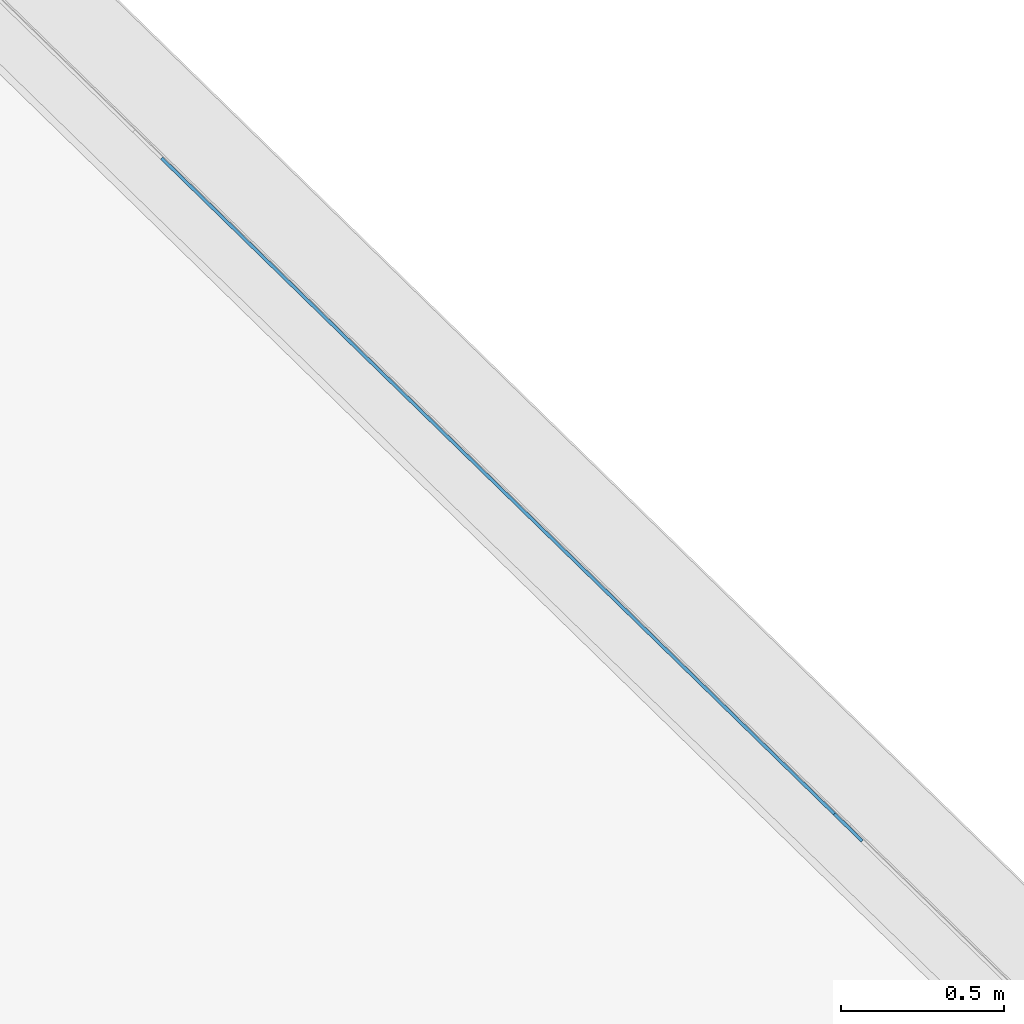
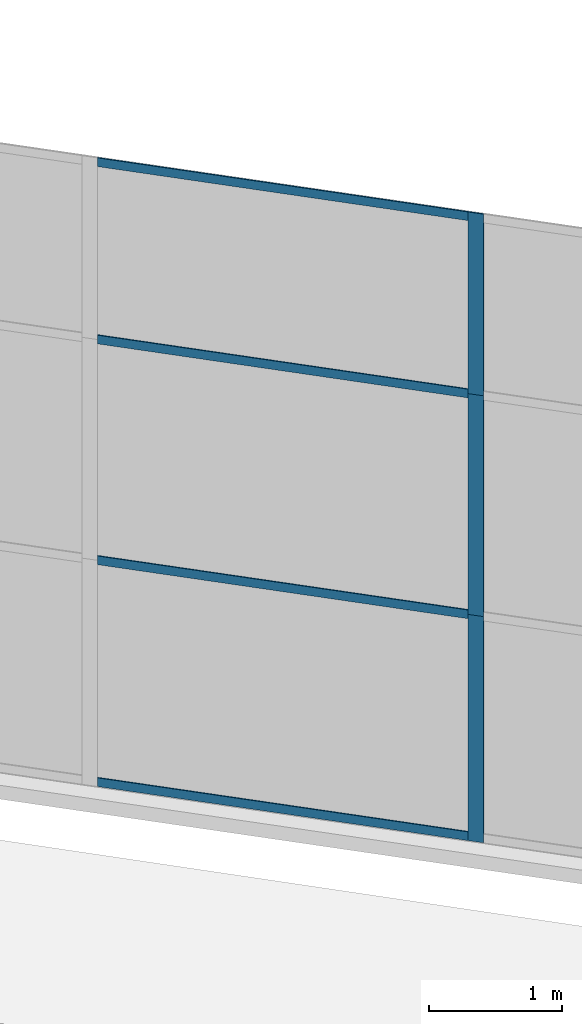
# One storey, part 4 of 13: 7 members, 1 element without a shape of its own.
"""IFC4 building model written with IfcOpenShell, lengths in metres."""

from ifc_helpers import new_model, entity, si_unit, converted_unit, direction, frame, origin, place, context, subcontext, project, spatial, indexed_curve, outline, extrude, source, transform, mapped, material, type_object, type_shapes, element, aggregate, save


model = new_model("IFC4")

# Units and contexts
model_context = context("Model", 3, precision=1e-05, world=origin(), true_north=direction((6.123233995736766e-17, 1.0)))
body_context = subcontext(model_context, "Body", "Model", "MODEL_VIEW")
ifc_project = project(units=[si_unit("LENGTHUNIT", "METRE"), si_unit("AREAUNIT", "SQUARE_METRE"), si_unit("VOLUMEUNIT", "CUBIC_METRE"), converted_unit("PLANEANGLEUNIT", "DEGREE", entity("IfcPlaneAngleMeasure", 0.017453292519943278), si_unit("PLANEANGLEUNIT", "RADIAN"), dimensions=[0, 0, 0, 0, 0, 0, 0])], contexts=[model_context])

# Site, building, storey
site_placement = place(None, frame((0.0, 0.0, 0.0), z_axis=(0.0, 0.0, 1.0), x_axis=(0.7160934825303189, -0.6980043870045516, 0.0)))
site = spatial("IfcSite", under=ifc_project, at=site_placement, CompositionType="ELEMENT")
building_placement = place(site_placement, origin())
building = spatial("IfcBuilding", under=site, at=building_placement, CompositionType="ELEMENT")
storey_placement = place(building_placement, frame((0.0, 0.0, -7.0)))
storey = spatial("IfcBuildingStorey", under=building, at=storey_placement, Name="-7.00 m", CompositionType="ELEMENT", Elevation=-7.000000000000001)

# Curtain wall, members
curtain_wall_type = type_object("IfcCurtainWallType", Name="Facciata continua:Vetrata_2", PredefinedType="NOTDEFINED")
curtain_wall_placement = place(storey_placement, frame((0.0, 0.0, 7.0)))
curtain_wall = element("IfcCurtainWall", 1, at=curtain_wall_placement, inside=storey, type_object=curtain_wall_type, Name="Facciata continua:Vetrata_2", ObjectType="Facciata continua:Vetrata_2", PredefinedType="NOTDEFINED")
ifc_material = material(Name="Acciaio", Category="Metallo")
member_type_1 = type_object("IfcMemberType", Name="Montante rettangolare:Montante rettangolare 2", PredefinedType="MULLION", material=ifc_material)
shared_shape_1 = source(origin(), body_context, "Body", "SweptSolid", [
    extrude(outline(indexed_curve([(-0.04, -0.004999999999999997), (0.04, -0.004999999999999997), (0.04, 0.004999999999999997), (-0.04, 0.004999999999999997), (-0.04, -0.004999999999999997)], self_intersect=False)), frame((-0.04, 0.009999999999999993, -2.8811750164301526), z_axis=(0.0, 0.0, 1.0), x_axis=(-1.0, 0.0, 0.0)), (0.0, 0.0, 1.0), 2.881175016430152),
])
type_shapes(member_type_1, [shared_shape_1])
member_1_placement = place(curtain_wall_placement, frame((-3.7827352408591794, -6.977854376535852, -1.1600000000000001), z_axis=(1.0, 0.0, 0.0), x_axis=(0.0, 0.0, 1.0)))
member_1 = element("IfcMember", 2, at=member_1_placement, type_object=member_type_1, material=ifc_material, Name="Montante rettangolare:Montante rettangolare 2", ObjectType="Montante rettangolare:Montante rettangolare 2", PredefinedType="MULLION", context=body_context, shape_type="MappedRepresentation", body=[
    mapped(shared_shape_1, transform((0.0, 0.0, 0.0), scale=1.0)),
])
member_type_2 = type_object("IfcMemberType", Name="Montante rettangolare:Montante rettangolare 2", PredefinedType="MULLION", material=ifc_material)
shared_shape_2 = source(origin(), body_context, "Body", "SweptSolid", [
    extrude(outline(indexed_curve([(-0.04, -0.004999999999999997), (0.04, -0.004999999999999997), (0.04, 0.004999999999999997), (-0.04, 0.004999999999999997), (-0.04, -0.004999999999999997)], self_intersect=False)), frame((-0.04, 0.009999999999999993, -2.8811750164301455), z_axis=(0.0, 0.0, 1.0), x_axis=(-1.0, 0.0, 0.0)), (0.0, 0.0, 1.0), 2.8811750164301437),
])
type_shapes(member_type_2, [shared_shape_2])
member_2_placement = place(curtain_wall_placement, frame((-6.663910257289318, -6.977854376535842, -6.94), z_axis=(-1.0, 0.0, 0.0), x_axis=(0.0, 0.0, -1.0)))
member_2 = element("IfcMember", 3, at=member_2_placement, type_object=member_type_2, material=ifc_material, Name="Montante rettangolare:Montante rettangolare 2", ObjectType="Montante rettangolare:Montante rettangolare 2", PredefinedType="MULLION", context=body_context, shape_type="MappedRepresentation", body=[
    mapped(shared_shape_2, transform((0.0, 0.0, 0.0), scale=1.0)),
])
member_type_3 = type_object("IfcMemberType", Name="Montante rettangolare:Montante rettangolare 2", PredefinedType="MULLION", material=ifc_material)
shared_shape_3 = source(origin(), body_context, "Body", "SweptSolid", [
    extrude(outline(indexed_curve([(-0.04, -0.005000000000000001), (0.04, -0.005000000000000001), (0.04, 0.005000000000000001), (-0.04, 0.005000000000000001), (-0.04, -0.005000000000000001)], self_intersect=False)), frame((0.0, 0.009999999999999998, -2.8811750164301433), z_axis=(0.0, 0.0, 1.0), x_axis=(-1.0, 0.0, 0.0)), (0.0, 0.0, 1.0), 2.8811750164301437),
])
type_shapes(member_type_3, [shared_shape_3])
member_3_placement = place(curtain_wall_placement, frame((-3.7827352408591794, -6.977854376535852, -2.829999999999999), z_axis=(1.0, 0.0, 0.0), x_axis=(0.0, 0.0, 1.0)))
member_3 = element("IfcMember", 4, at=member_3_placement, type_object=member_type_3, material=ifc_material, Name="Montante rettangolare:Montante rettangolare 2", ObjectType="Montante rettangolare:Montante rettangolare 2", PredefinedType="MULLION", context=body_context, shape_type="MappedRepresentation", body=[
    mapped(shared_shape_3, transform((0.0, 0.0, 0.0), scale=1.0)),
])
member_4_placement = place(curtain_wall_placement, frame((-3.7827352408591794, -6.977854376535852, -4.86), z_axis=(1.0, 0.0, 0.0), x_axis=(0.0, 0.0, 1.0)))
member_4 = element("IfcMember", 5, at=member_4_placement, type_object=member_type_3, material=ifc_material, Name="Montante rettangolare:Montante rettangolare 2", ObjectType="Montante rettangolare:Montante rettangolare 2", PredefinedType="MULLION", context=body_context, shape_type="MappedRepresentation", body=[
    mapped(shared_shape_3, transform((0.0, 0.0, 0.0), scale=1.0)),
])
member_type_4 = type_object("IfcMemberType", Name="Montante rettangolare:Montante rettangolare 3", PredefinedType="MULLION", material=ifc_material)
shared_shape_4 = source(origin(), body_context, "Body", "SweptSolid", [
    extrude(outline(indexed_curve([(-0.06, -0.005000000000000001), (0.06, -0.005000000000000001), (0.06, 0.005000000000000001), (-0.06, 0.005000000000000001), (-0.06, -0.005000000000000001)], self_intersect=False)), frame((0.0, 0.009999999999999998, -2.0800000000000005), z_axis=(0.0, 0.0, 1.0), x_axis=(-1.0, 0.0, 0.0)), (0.0, 0.0, 1.0), 2.0800000000000005),
])
type_shapes(member_type_4, [shared_shape_4])
member_5_placement = place(curtain_wall_placement, frame((-3.7227352408591794, -6.977854376535852, -6.94), z_axis=(0.0, 0.0, -1.0), x_axis=(1.0, 0.0, 0.0)))
member_5 = element("IfcMember", 6, at=member_5_placement, type_object=member_type_4, material=ifc_material, Name="Montante rettangolare:Montante rettangolare 3", ObjectType="Montante rettangolare:Montante rettangolare 3", PredefinedType="MULLION", context=body_context, shape_type="MappedRepresentation", body=[
    mapped(shared_shape_4, transform((0.0, 0.0, 0.0), scale=1.0)),
])
member_type_5 = type_object("IfcMemberType", Name="Montante rettangolare:Montante rettangolare 3", PredefinedType="MULLION", material=ifc_material)
shared_shape_5 = source(origin(), body_context, "Body", "SweptSolid", [
    extrude(outline(indexed_curve([(-0.06, -0.005000000000000001), (0.06, -0.005000000000000001), (0.06, 0.005000000000000001), (-0.06, 0.005000000000000001), (-0.06, -0.005000000000000001)], self_intersect=False)), frame((0.0, 0.009999999999999998, -1.6699999999999993), z_axis=(0.0, 0.0, 1.0), x_axis=(-1.0, 0.0, 0.0)), (0.0, 0.0, 1.0), 1.6699999999999993),
])
type_shapes(member_type_5, [shared_shape_5])
member_6_placement = place(curtain_wall_placement, frame((-3.7227352408591794, -6.977854376535852, -2.829999999999999), z_axis=(0.0, 0.0, -1.0), x_axis=(1.0, 0.0, 0.0)))
member_6 = element("IfcMember", 7, at=member_6_placement, type_object=member_type_5, material=ifc_material, Name="Montante rettangolare:Montante rettangolare 3", ObjectType="Montante rettangolare:Montante rettangolare 3", PredefinedType="MULLION", context=body_context, shape_type="MappedRepresentation", body=[
    mapped(shared_shape_5, transform((0.0, 0.0, 0.0), scale=1.0)),
])
member_type_6 = type_object("IfcMemberType", Name="Montante rettangolare:Montante rettangolare 3", PredefinedType="MULLION", material=ifc_material)
shared_shape_6 = source(origin(), body_context, "Body", "SweptSolid", [
    extrude(outline(indexed_curve([(-0.06, -0.005000000000000001), (0.06, -0.005000000000000001), (0.06, 0.005000000000000001), (-0.06, 0.005000000000000001), (-0.06, -0.005000000000000001)], self_intersect=False)), frame((0.0, 0.009999999999999998, -2.030000000000001), z_axis=(0.0, 0.0, 1.0), x_axis=(-1.0, 0.0, 0.0)), (0.0, 0.0, 1.0), 2.030000000000001),
])
type_shapes(member_type_6, [shared_shape_6])
member_7_placement = place(curtain_wall_placement, frame((-3.7227352408591794, -6.977854376535852, -4.86), z_axis=(0.0, 0.0, -1.0), x_axis=(1.0, 0.0, 0.0)))
member_7 = element("IfcMember", 8, at=member_7_placement, type_object=member_type_6, material=ifc_material, Name="Montante rettangolare:Montante rettangolare 3", ObjectType="Montante rettangolare:Montante rettangolare 3", PredefinedType="MULLION", context=body_context, shape_type="MappedRepresentation", body=[
    mapped(shared_shape_6, transform((0.0, 0.0, 0.0), scale=1.0)),
])
aggregate(curtain_wall, [member_1, member_2, member_3, member_4, member_5, member_6, member_7])

save(model, "model.ifc")
